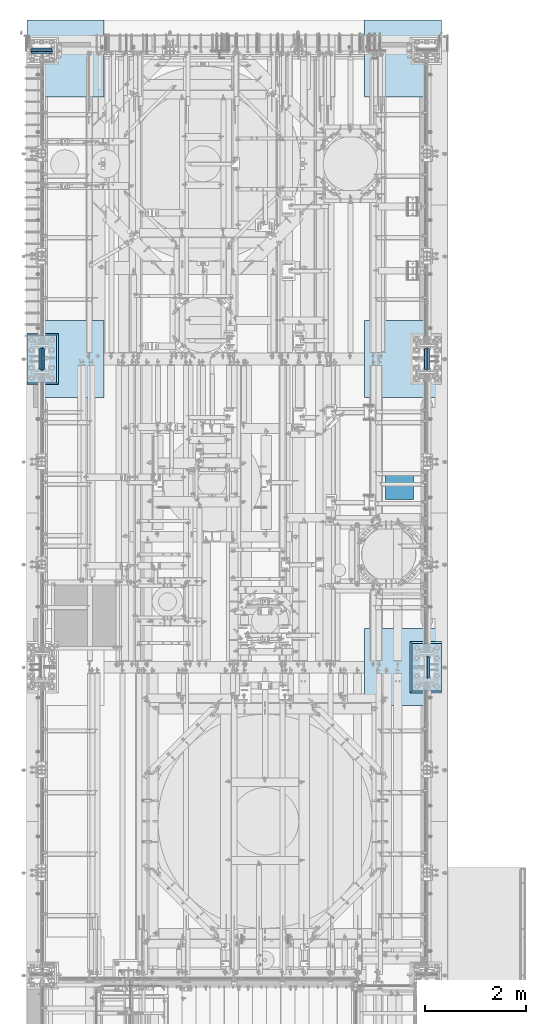
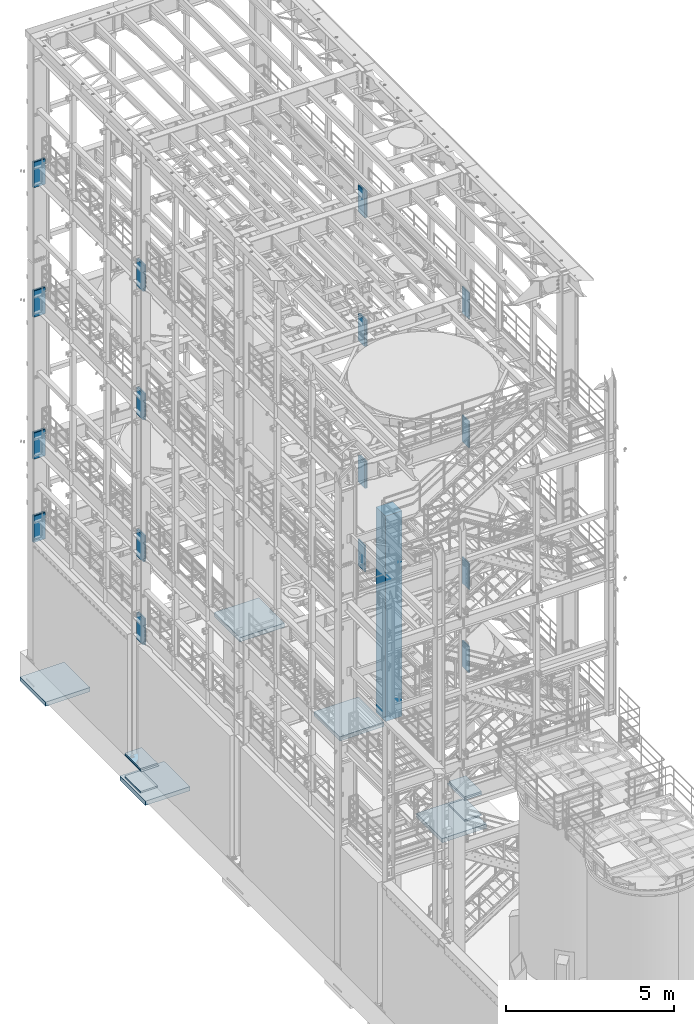
# One storey, part 1403 of 1876: 34 plates, 5 slabs, 18 elements without a shape of their own.
"""IFC2X3 building model written with IfcOpenShell, lengths in millimetres."""

from ifc_helpers import new_model, si_unit, frame, origin_with_axes, place, context, subcontext, project, spatial, faceted_brep, material, type_object, element, aggregate, save


model = new_model("IFC2X3")

# Units and contexts
model_context = context("Model", 3, precision=1e-05, world=origin_with_axes())
body_context = subcontext(model_context, "Body", "Model", "MODEL_VIEW")
ifc_project = project(units=[si_unit("LENGTHUNIT", "METRE", prefix="MILLI"), si_unit("AREAUNIT", "SQUARE_METRE"), si_unit("VOLUMEUNIT", "CUBIC_METRE"), si_unit("MASSUNIT", "GRAM", prefix="KILO"), si_unit("TIMEUNIT", "SECOND"), si_unit("PLANEANGLEUNIT", "RADIAN"), si_unit("SOLIDANGLEUNIT", "STERADIAN"), si_unit("THERMODYNAMICTEMPERATUREUNIT", "DEGREE_CELSIUS"), si_unit("LUMINOUSINTENSITYUNIT", "LUMEN")], contexts=[model_context])

# Site, building, storey
site_placement = place(None, origin_with_axes())
site = spatial("IfcSite", under=ifc_project, at=site_placement, CompositionType="ELEMENT")
building_placement = place(site_placement, origin_with_axes())
building = spatial("IfcBuilding", under=site, at=building_placement, Name="Undefined", CompositionType="ELEMENT")
storey_placement = place(building_placement, origin_with_axes())
storey = spatial("IfcBuildingStorey", under=building, at=storey_placement, Name="Undefined", CompositionType="ELEMENT", Elevation=0.0)

# Assembly, plate
assembly_1_placement = place(storey_placement, origin_with_axes())
assembly_1 = element("IfcElementAssembly", 1, at=assembly_1_placement, inside=storey, Name="PLATE", AssemblyPlace="NOTDEFINED", PredefinedType="RIGID_FRAME")
ifc_material_1 = material(Name="STEEL/A36")
plate_type_1 = type_object("IfcPlateType", PredefinedType="NOTDEFINED")
plate_1_placement = place(assembly_1_placement, frame((6797.675, 5395.9125, 4456.90625), z_axis=(1.0, 0.0, 0.0), x_axis=(0.0, -1.0, 0.0)))
plate_1 = element("IfcPlate", 2, at=plate_1_placement, type_object=plate_type_1, material=ifc_material_1, Name="PLATE", context=body_context, shape_type="Brep", body=[
    faceted_brep([(0.0, -3733.8, 0.0), (0.0, -3733.8, 558.799926757812), (0.0, 3733.8, 558.799926757812), (0.0, 3733.8, 0.0), (558.799926757812, -3733.8, 558.799926757812), (558.799926757812, 3733.8, 558.799926757812), (558.799926757812, -3733.8, 0.0), (558.799926757812, 3733.8, 0.0)], [[[0, 1, 2, 3]], [[1, 4, 5, 2]], [[4, 6, 7, 5]], [[6, 0, 3, 7]], [[5, 7, 3, 2]], [[6, 4, 1, 0]]]),
])
aggregate(assembly_1, [plate_1])

assembly_2_placement = place(storey_placement, origin_with_axes())
assembly_2 = element("IfcElementAssembly", 3, at=assembly_2_placement, inside=storey, Name="COLUMN", AssemblyPlace="NOTDEFINED", PredefinedType="RIGID_FRAME")
ifc_material_2 = material(Name="STEEL/A572-GR.50")
plate_type_2 = type_object("IfcPlateType", PredefinedType="NOTDEFINED")
plate_2_placement = place(assembly_2_placement, frame((7649.36875, 1304.925, 18135.6), z_axis=(0.0, 1.0, 0.0), x_axis=(0.0, 0.0, -1.0)))
plate_2 = element("IfcPlate", 4, at=plate_2_placement, type_object=plate_type_2, material=ifc_material_2, Name="PLATE", context=body_context, shape_type="Brep", body=[
    faceted_brep([(0.0, -19.0500000000002, 416.152954749452), (952.5, -19.0500000000002, 416.152954749464), (952.5, 19.0500000000002, 438.149993896484), (0.0, 19.0500000000002, 438.149993896484), (952.5, -19.0500000000002, 21.997045250647), (952.5, 19.0500000000002, 0.0), (-9.09494701772928e-13, 19.05, -1.81898940354586e-12), (0.0, -19.0500000000002, 21.9970452506512)], [[[0, 1, 2, 3]], [[2, 1, 4, 5]], [[3, 2, 5, 6]], [[0, 3, 6, 7]], [[1, 0, 7, 4]], [[6, 5, 4, 7]]]),
])
aggregate(assembly_2, [plate_2])

# Assembly, plates
assembly_3_placement = place(storey_placement, origin_with_axes())
assembly_3 = element("IfcElementAssembly", 5, at=assembly_3_placement, inside=storey, Name="COLUMN", AssemblyPlace="NOTDEFINED", PredefinedType="RIGID_FRAME")
plate_3_placement = place(assembly_3_placement, frame((7590.63125, 7400.925, 18135.6), z_axis=(0.0, 1.0, 0.0), x_axis=(0.0, 0.0, -1.0)))
plate_3 = element("IfcPlate", 6, at=plate_3_placement, type_object=plate_type_2, material=ifc_material_2, Name="PLATE", context=body_context, shape_type="Brep", body=[
    faceted_brep([(0.0, 19.0500000000002, 416.152954742277), (0.0, -19.0500000000002, 438.149993896484), (952.5, -19.0500000000002, 438.149993896484), (952.5, 19.0500000000002, 416.152954742277), (952.5, 19.0500000000002, 21.9970452577367), (0.0, 19.0500000000002, 21.9970452577367), (0.0, -19.0500000000002, 0.0), (952.5, -19.0500000000002, 0.0)], [[[0, 1, 2, 3]], [[0, 3, 4, 5]], [[1, 0, 5, 6]], [[2, 1, 6, 7]], [[3, 2, 7, 4]], [[6, 5, 4, 7]]]),
])
plate_4_placement = place(assembly_3_placement, frame((7649.36875, 7400.925, 18135.6), z_axis=(0.0, 1.0, 0.0), x_axis=(0.0, 0.0, -1.0)))
plate_4 = element("IfcPlate", 7, at=plate_4_placement, type_object=plate_type_2, material=ifc_material_2, Name="PLATE", context=body_context, shape_type="Brep", body=[
    faceted_brep([(0.0, -19.0500000000002, 416.152954749452), (952.5, -19.0500000000002, 416.152954749464), (952.5, 19.0500000000002, 438.149993896484), (0.0, 19.0500000000002, 438.149993896484), (952.5, -19.0500000000002, 21.997045250647), (952.5, 19.0500000000002, 0.0), (-9.09494701772928e-13, 19.05, -1.81898940354586e-12), (0.0, -19.0500000000002, 21.9970452506512)], [[[0, 1, 2, 3]], [[2, 1, 4, 5]], [[3, 2, 5, 6]], [[0, 3, 6, 7]], [[1, 0, 7, 4]], [[6, 5, 4, 7]]]),
])
aggregate(assembly_3, [plate_3, plate_4])

assembly_4_placement = place(storey_placement, origin_with_axes())
assembly_4 = element("IfcElementAssembly", 8, at=assembly_4_placement, inside=storey, Name="COLUMN", AssemblyPlace="NOTDEFINED", PredefinedType="RIGID_FRAME")
plate_5_placement = place(assembly_4_placement, frame((219.075, 13685.04375, 18135.6), z_axis=(-1.0, 0.0, 0.0), x_axis=(0.0, 0.0, -1.0)))
plate_5 = element("IfcPlate", 9, at=plate_5_placement, type_object=plate_type_2, material=ifc_material_2, Name="PLATE", context=body_context, shape_type="Brep", body=[
    faceted_brep([(0.0, 19.0500000000002, 416.152954742277), (0.0, -19.0500000000002, 438.149993896484), (920.75, -19.0500000000002, 438.149993896484), (920.75, 19.0500000000002, 416.152954742198), (920.75, 19.0500000000002, 21.9970452577326), (0.0, 19.0500000000002, 21.9970452577367), (0.0, -19.0500000000002, 0.0), (920.75, -19.0500000000002, 0.0)], [[[0, 1, 2, 3]], [[0, 3, 4, 5]], [[1, 0, 5, 6]], [[2, 1, 6, 7]], [[3, 2, 7, 4]], [[6, 5, 4, 7]]]),
])
plate_6_placement = place(assembly_4_placement, frame((219.075, 13746.95625, 18135.6), z_axis=(-1.0, 0.0, 0.0), x_axis=(0.0, 0.0, -1.0)))
plate_6 = element("IfcPlate", 10, at=plate_6_placement, type_object=plate_type_2, material=ifc_material_2, Name="PLATE", context=body_context, shape_type="Brep", body=[
    faceted_brep([(0.0, -19.0500000000002, 416.152954749452), (920.75, -19.0500000000002, 416.152954749452), (920.75, 19.0500000000002, 438.149993896484), (0.0, 19.0500000000002, 438.149993896484), (920.75, -19.0500000000002, 21.9970452506512), (920.75, 19.0500000000002, 0.0), (-9.09494701772928e-13, 19.05, -1.81898940354586e-12), (0.0, -19.0500000000002, 21.9970452506512)], [[[0, 1, 2, 3]], [[2, 1, 4, 5]], [[3, 2, 5, 6]], [[0, 3, 6, 7]], [[1, 0, 7, 4]], [[6, 5, 4, 7]]]),
])
aggregate(assembly_4, [plate_5, plate_6])

assembly_5_placement = place(storey_placement, origin_with_axes())
assembly_5 = element("IfcElementAssembly", 11, at=assembly_5_placement, inside=storey, Name="COLUMN", AssemblyPlace="NOTDEFINED", PredefinedType="RIGID_FRAME")
plate_7_placement = place(assembly_5_placement, frame((29.3687499999999, 7839.075, 18135.6), z_axis=(0.0, -1.0, 0.0), x_axis=(0.0, 0.0, -1.0)))
plate_7 = element("IfcPlate", 12, at=plate_7_placement, type_object=plate_type_2, material=ifc_material_2, Name="PLATE", context=body_context, shape_type="Brep", body=[
    faceted_brep([(0.0, 19.0500000000002, 416.152954742277), (0.0, -19.0500000000002, 438.149993896484), (952.5, -19.0500000000002, 438.149993896484), (952.5, 19.0500000000002, 416.152954742277), (952.5, 19.0500000000002, 21.9970452577367), (0.0, 19.0500000000002, 21.9970452577367), (0.0, -19.0500000000002, 0.0), (952.5, -19.0500000000002, 0.0)], [[[0, 1, 2, 3]], [[0, 3, 4, 5]], [[1, 0, 5, 6]], [[2, 1, 6, 7]], [[3, 2, 7, 4]], [[6, 5, 4, 7]]]),
])
plate_8_placement = place(assembly_5_placement, frame((-29.3687499999999, 7839.075, 18135.6), z_axis=(0.0, -1.0, 0.0), x_axis=(0.0, 0.0, -1.0)))
plate_8 = element("IfcPlate", 13, at=plate_8_placement, type_object=plate_type_2, material=ifc_material_2, Name="PLATE", context=body_context, shape_type="Brep", body=[
    faceted_brep([(0.0, -19.0500000000002, 416.152954749452), (952.5, -19.0500000000002, 416.152954749464), (952.5, 19.0500000000002, 438.149993896484), (0.0, 19.0500000000002, 438.149993896484), (952.5, -19.0500000000002, 21.997045250647), (952.5, 19.0500000000002, 0.0), (-9.09494701772928e-13, 19.05, -1.81898940354586e-12), (0.0, -19.0500000000002, 21.9970452506512)], [[[0, 1, 2, 3]], [[2, 1, 4, 5]], [[3, 2, 5, 6]], [[0, 3, 6, 7]], [[1, 0, 7, 4]], [[6, 5, 4, 7]]]),
])
aggregate(assembly_5, [plate_7, plate_8])

assembly_6_placement = place(storey_placement, origin_with_axes())
assembly_6 = element("IfcElementAssembly", 14, at=assembly_6_placement, inside=storey, Name="COLUMN", AssemblyPlace="NOTDEFINED", PredefinedType="RIGID_FRAME")
plate_9_placement = place(assembly_6_placement, frame((29.3687499999999, 7839.075, 13462.0), z_axis=(0.0, -1.0, 0.0), x_axis=(0.0, 0.0, -1.0)))
plate_9 = element("IfcPlate", 15, at=plate_9_placement, type_object=plate_type_2, material=ifc_material_2, Name="PLATE", context=body_context, shape_type="Brep", body=[
    faceted_brep([(0.0, 19.0500000000002, 416.152954742277), (0.0, -19.0500000000002, 438.149993896484), (952.5, -19.0500000000002, 438.149993896484), (952.5, 19.0500000000002, 416.152954742277), (952.5, 19.0500000000002, 21.9970452577367), (0.0, 19.0500000000002, 21.9970452577367), (0.0, -19.0500000000002, 0.0), (952.5, -19.0500000000002, 0.0)], [[[0, 1, 2, 3]], [[0, 3, 4, 5]], [[1, 0, 5, 6]], [[2, 1, 6, 7]], [[3, 2, 7, 4]], [[6, 5, 4, 7]]]),
])
plate_10_placement = place(assembly_6_placement, frame((-29.3687499999999, 7839.075, 13462.0), z_axis=(0.0, -1.0, 0.0), x_axis=(0.0, 0.0, -1.0)))
plate_10 = element("IfcPlate", 16, at=plate_10_placement, type_object=plate_type_2, material=ifc_material_2, Name="PLATE", context=body_context, shape_type="Brep", body=[
    faceted_brep([(0.0, -19.0500000000002, 416.152954749452), (952.5, -19.0500000000002, 416.152954749464), (952.5, 19.0500000000002, 438.149993896484), (0.0, 19.0500000000002, 438.149993896484), (952.5, -19.0500000000002, 21.997045250647), (952.5, 19.0500000000002, 0.0), (-9.09494701772928e-13, 19.05, -1.81898940354586e-12), (0.0, -19.0500000000002, 21.9970452506512)], [[[0, 1, 2, 3]], [[2, 1, 4, 5]], [[3, 2, 5, 6]], [[0, 3, 6, 7]], [[1, 0, 7, 4]], [[6, 5, 4, 7]]]),
])
plate_11_placement = place(assembly_6_placement, frame((29.3687499999999, 7839.075, 8305.8), z_axis=(0.0, -1.0, 0.0), x_axis=(0.0, 0.0, -1.0)))
plate_11 = element("IfcPlate", 17, at=plate_11_placement, type_object=plate_type_2, material=ifc_material_2, Name="PLATE", context=body_context, shape_type="Brep", body=[
    faceted_brep([(0.0, 19.0500000000002, 416.152954742277), (0.0, -19.0500000000002, 438.149993896484), (952.5, -19.0500000000002, 438.149993896484), (952.5, 19.0500000000002, 416.152954742277), (952.5, 19.0500000000002, 21.9970452577367), (0.0, 19.0500000000002, 21.9970452577367), (0.0, -19.0500000000002, 0.0), (952.5, -19.0500000000002, 0.0)], [[[0, 1, 2, 3]], [[0, 3, 4, 5]], [[1, 0, 5, 6]], [[2, 1, 6, 7]], [[3, 2, 7, 4]], [[6, 5, 4, 7]]]),
])
plate_12_placement = place(assembly_6_placement, frame((-29.3687499999999, 7839.075, 8305.8), z_axis=(0.0, -1.0, 0.0), x_axis=(0.0, 0.0, -1.0)))
plate_12 = element("IfcPlate", 18, at=plate_12_placement, type_object=plate_type_2, material=ifc_material_2, Name="PLATE", context=body_context, shape_type="Brep", body=[
    faceted_brep([(0.0, -19.0500000000002, 416.152954749452), (952.5, -19.0500000000002, 416.152954749464), (952.5, 19.0500000000002, 438.149993896484), (0.0, 19.0500000000002, 438.149993896484), (952.5, -19.0500000000002, 21.997045250647), (952.5, 19.0500000000002, 0.0), (-9.09494701772928e-13, 19.05, -1.81898940354586e-12), (0.0, -19.0500000000002, 21.9970452506512)], [[[0, 1, 2, 3]], [[2, 1, 4, 5]], [[3, 2, 5, 6]], [[0, 3, 6, 7]], [[1, 0, 7, 4]], [[6, 5, 4, 7]]]),
])

# Assembly, plate
assembly_7_placement = place(storey_placement, origin_with_axes())
assembly_7 = element("IfcElementAssembly", 19, at=assembly_7_placement, inside=storey, Name="COLUMN", AssemblyPlace="NOTDEFINED", PredefinedType="RIGID_FRAME")
plate_13_placement = place(assembly_7_placement, frame((7649.36875, 1304.925, 13462.0), z_axis=(0.0, 1.0, 0.0), x_axis=(0.0, 0.0, -1.0)))
plate_13 = element("IfcPlate", 20, at=plate_13_placement, type_object=plate_type_2, material=ifc_material_2, Name="PLATE", context=body_context, shape_type="Brep", body=[
    faceted_brep([(0.0, -19.0500000000002, 416.152954749452), (952.5, -19.0500000000002, 416.152954749464), (952.5, 19.0500000000002, 438.149993896484), (0.0, 19.0500000000002, 438.149993896484), (952.5, -19.0500000000002, 21.997045250647), (952.5, 19.0500000000002, 0.0), (-9.09494701772928e-13, 19.05, -1.81898940354586e-12), (0.0, -19.0500000000002, 21.9970452506512)], [[[0, 1, 2, 3]], [[2, 1, 4, 5]], [[3, 2, 5, 6]], [[0, 3, 6, 7]], [[1, 0, 7, 4]], [[6, 5, 4, 7]]]),
])

# Assembly, plates
assembly_8_placement = place(storey_placement, origin_with_axes())
assembly_8 = element("IfcElementAssembly", 21, at=assembly_8_placement, inside=storey, Name="COLUMN", AssemblyPlace="NOTDEFINED", PredefinedType="RIGID_FRAME")
plate_14_placement = place(assembly_8_placement, frame((7590.63125, 7400.925, 13462.0), z_axis=(0.0, 1.0, 0.0), x_axis=(0.0, 0.0, -1.0)))
plate_14 = element("IfcPlate", 22, at=plate_14_placement, type_object=plate_type_2, material=ifc_material_2, Name="PLATE", context=body_context, shape_type="Brep", body=[
    faceted_brep([(0.0, 19.0500000000002, 416.152954742277), (0.0, -19.0500000000002, 438.149993896484), (952.5, -19.0500000000002, 438.149993896484), (952.5, 19.0500000000002, 416.152954742277), (952.5, 19.0500000000002, 21.9970452577367), (0.0, 19.0500000000002, 21.9970452577367), (0.0, -19.0500000000002, 0.0), (952.5, -19.0500000000002, 0.0)], [[[0, 1, 2, 3]], [[0, 3, 4, 5]], [[1, 0, 5, 6]], [[2, 1, 6, 7]], [[3, 2, 7, 4]], [[6, 5, 4, 7]]]),
])
plate_15_placement = place(assembly_8_placement, frame((7649.36875, 7400.925, 13462.0), z_axis=(0.0, 1.0, 0.0), x_axis=(0.0, 0.0, -1.0)))
plate_15 = element("IfcPlate", 23, at=plate_15_placement, type_object=plate_type_2, material=ifc_material_2, Name="PLATE", context=body_context, shape_type="Brep", body=[
    faceted_brep([(0.0, -19.0500000000002, 416.152954749452), (952.5, -19.0500000000002, 416.152954749464), (952.5, 19.0500000000002, 438.149993896484), (0.0, 19.0500000000002, 438.149993896484), (952.5, -19.0500000000002, 21.997045250647), (952.5, 19.0500000000002, 0.0), (-9.09494701772928e-13, 19.05, -1.81898940354586e-12), (0.0, -19.0500000000002, 21.9970452506512)], [[[0, 1, 2, 3]], [[2, 1, 4, 5]], [[3, 2, 5, 6]], [[0, 3, 6, 7]], [[1, 0, 7, 4]], [[6, 5, 4, 7]]]),
])

assembly_9_placement = place(storey_placement, origin_with_axes())
assembly_9 = element("IfcElementAssembly", 24, at=assembly_9_placement, inside=storey, Name="COLUMN", AssemblyPlace="NOTDEFINED", PredefinedType="RIGID_FRAME")
plate_16_placement = place(assembly_9_placement, frame((219.075, 13685.04375, 13462.0), z_axis=(-1.0, 0.0, 0.0), x_axis=(0.0, 0.0, -1.0)))
plate_16 = element("IfcPlate", 25, at=plate_16_placement, type_object=plate_type_2, material=ifc_material_2, Name="PLATE", context=body_context, shape_type="Brep", body=[
    faceted_brep([(0.0, 19.0500000000002, 416.152954742277), (0.0, -19.0500000000002, 438.149993896484), (952.5, -19.0500000000002, 438.149993896484), (952.5, 19.0500000000002, 416.152954742277), (952.5, 19.0500000000002, 21.9970452577367), (0.0, 19.0500000000002, 21.9970452577367), (0.0, -19.0500000000002, 0.0), (952.5, -19.0500000000002, 0.0)], [[[0, 1, 2, 3]], [[0, 3, 4, 5]], [[1, 0, 5, 6]], [[2, 1, 6, 7]], [[3, 2, 7, 4]], [[6, 5, 4, 7]]]),
])
plate_17_placement = place(assembly_9_placement, frame((219.075, 13746.95625, 13462.0), z_axis=(-1.0, 0.0, 0.0), x_axis=(0.0, 0.0, -1.0)))
plate_17 = element("IfcPlate", 26, at=plate_17_placement, type_object=plate_type_2, material=ifc_material_2, Name="PLATE", context=body_context, shape_type="Brep", body=[
    faceted_brep([(0.0, -19.0500000000002, 416.152954749452), (952.5, -19.0500000000002, 416.152954749464), (952.5, 19.0500000000002, 438.149993896484), (0.0, 19.0500000000002, 438.149993896484), (952.5, -19.0500000000002, 21.997045250647), (952.5, 19.0500000000002, 0.0), (-9.09494701772928e-13, 19.05, -1.81898940354586e-12), (0.0, -19.0500000000002, 21.9970452506512)], [[[0, 1, 2, 3]], [[2, 1, 4, 5]], [[3, 2, 5, 6]], [[0, 3, 6, 7]], [[1, 0, 7, 4]], [[6, 5, 4, 7]]]),
])

# Plate
plate_18_placement = place(assembly_7_placement, frame((7649.36875, 1304.925, 8305.8), z_axis=(0.0, 1.0, 0.0), x_axis=(0.0, 0.0, -1.0)))
plate_18 = element("IfcPlate", 27, at=plate_18_placement, type_object=plate_type_2, material=ifc_material_2, Name="PLATE", context=body_context, shape_type="Brep", body=[
    faceted_brep([(0.0, -19.0500000000002, 416.152954749452), (952.5, -19.0500000000002, 416.152954749464), (952.5, 19.0500000000002, 438.149993896484), (0.0, 19.0500000000002, 438.149993896484), (952.5, -19.0500000000002, 21.997045250647), (952.5, 19.0500000000002, 0.0), (-9.09494701772928e-13, 19.05, -1.81898940354586e-12), (0.0, -19.0500000000002, 21.9970452506512)], [[[0, 1, 2, 3]], [[2, 1, 4, 5]], [[3, 2, 5, 6]], [[0, 3, 6, 7]], [[1, 0, 7, 4]], [[6, 5, 4, 7]]]),
])

plate_19_placement = place(assembly_8_placement, frame((7590.63125, 7400.925, 8305.8), z_axis=(0.0, 1.0, 0.0), x_axis=(0.0, 0.0, -1.0)))
plate_19 = element("IfcPlate", 28, at=plate_19_placement, type_object=plate_type_2, material=ifc_material_2, Name="PLATE", context=body_context, shape_type="Brep", body=[
    faceted_brep([(0.0, 19.0500000000002, 416.152954742277), (0.0, -19.0500000000002, 438.149993896484), (952.5, -19.0500000000002, 438.149993896484), (952.5, 19.0500000000002, 416.152954742277), (952.5, 19.0500000000002, 21.9970452577367), (0.0, 19.0500000000002, 21.9970452577367), (0.0, -19.0500000000002, 0.0), (952.5, -19.0500000000002, 0.0)], [[[0, 1, 2, 3]], [[0, 3, 4, 5]], [[1, 0, 5, 6]], [[2, 1, 6, 7]], [[3, 2, 7, 4]], [[6, 5, 4, 7]]]),
])

plate_20_placement = place(assembly_8_placement, frame((7649.36875, 7400.925, 8305.8), z_axis=(0.0, 1.0, 0.0), x_axis=(0.0, 0.0, -1.0)))
plate_20 = element("IfcPlate", 29, at=plate_20_placement, type_object=plate_type_2, material=ifc_material_2, Name="PLATE", context=body_context, shape_type="Brep", body=[
    faceted_brep([(0.0, -19.0500000000002, 416.152954749452), (952.5, -19.0500000000002, 416.152954749464), (952.5, 19.0500000000002, 438.149993896484), (0.0, 19.0500000000002, 438.149993896484), (952.5, -19.0500000000002, 21.997045250647), (952.5, 19.0500000000002, 0.0), (-9.09494701772928e-13, 19.05, -1.81898940354586e-12), (0.0, -19.0500000000002, 21.9970452506512)], [[[0, 1, 2, 3]], [[2, 1, 4, 5]], [[3, 2, 5, 6]], [[0, 3, 6, 7]], [[1, 0, 7, 4]], [[6, 5, 4, 7]]]),
])

plate_21_placement = place(assembly_7_placement, frame((7649.36875, 1304.925, 5283.2), z_axis=(0.0, 1.0, 0.0), x_axis=(0.0, 0.0, -1.0)))
plate_21 = element("IfcPlate", 30, at=plate_21_placement, type_object=plate_type_2, material=ifc_material_2, Name="PLATE", context=body_context, shape_type="Brep", body=[
    faceted_brep([(0.0, -19.0500000000002, 416.152954749452), (952.5, -19.0500000000002, 416.152954749464), (952.5, 19.0500000000002, 438.149993896484), (0.0, 19.0500000000002, 438.149993896484), (952.5, -19.0500000000002, 21.997045250647), (952.5, 19.0500000000002, 0.0), (-9.09494701772928e-13, 19.05, -1.81898940354586e-12), (0.0, -19.0500000000002, 21.9970452506512)], [[[0, 1, 2, 3]], [[2, 1, 4, 5]], [[3, 2, 5, 6]], [[0, 3, 6, 7]], [[1, 0, 7, 4]], [[6, 5, 4, 7]]]),
])

plate_22_placement = place(assembly_8_placement, frame((7590.63125, 7400.925, 5283.2), z_axis=(0.0, 1.0, 0.0), x_axis=(0.0, 0.0, -1.0)))
plate_22 = element("IfcPlate", 31, at=plate_22_placement, type_object=plate_type_2, material=ifc_material_2, Name="PLATE", context=body_context, shape_type="Brep", body=[
    faceted_brep([(0.0, 19.0500000000002, 416.152954742277), (0.0, -19.0500000000002, 438.149993896484), (952.5, -19.0500000000002, 438.149993896484), (952.5, 19.0500000000002, 416.152954742277), (952.5, 19.0500000000002, 21.9970452577367), (0.0, 19.0500000000002, 21.9970452577367), (0.0, -19.0500000000002, 0.0), (952.5, -19.0500000000002, 0.0)], [[[0, 1, 2, 3]], [[0, 3, 4, 5]], [[1, 0, 5, 6]], [[2, 1, 6, 7]], [[3, 2, 7, 4]], [[6, 5, 4, 7]]]),
])

aggregate(assembly_8, [plate_14, plate_15, plate_19, plate_20, plate_22])

plate_23_placement = place(assembly_6_placement, frame((29.3687499999999, 7839.075, 5283.2), z_axis=(0.0, -1.0, 0.0), x_axis=(0.0, 0.0, -1.0)))
plate_23 = element("IfcPlate", 32, at=plate_23_placement, type_object=plate_type_2, material=ifc_material_2, Name="PLATE", context=body_context, shape_type="Brep", body=[
    faceted_brep([(0.0, 19.0500000000002, 416.152954742277), (0.0, -19.0500000000002, 438.149993896484), (952.5, -19.0500000000002, 438.149993896484), (952.5, 19.0500000000002, 416.152954742277), (952.5, 19.0500000000002, 21.9970452577367), (0.0, 19.0500000000002, 21.9970452577367), (0.0, -19.0500000000002, 0.0), (952.5, -19.0500000000002, 0.0)], [[[0, 1, 2, 3]], [[0, 3, 4, 5]], [[1, 0, 5, 6]], [[2, 1, 6, 7]], [[3, 2, 7, 4]], [[6, 5, 4, 7]]]),
])

plate_24_placement = place(assembly_6_placement, frame((-29.3687499999999, 7839.075, 5283.2), z_axis=(0.0, -1.0, 0.0), x_axis=(0.0, 0.0, -1.0)))
plate_24 = element("IfcPlate", 33, at=plate_24_placement, type_object=plate_type_2, material=ifc_material_2, Name="PLATE", context=body_context, shape_type="Brep", body=[
    faceted_brep([(0.0, -19.0500000000002, 416.152954749452), (952.5, -19.0500000000002, 416.152954749464), (952.5, 19.0500000000002, 438.149993896484), (0.0, 19.0500000000002, 438.149993896484), (952.5, -19.0500000000002, 21.997045250647), (952.5, 19.0500000000002, 0.0), (-9.09494701772928e-13, 19.05, -1.81898940354586e-12), (0.0, -19.0500000000002, 21.9970452506512)], [[[0, 1, 2, 3]], [[2, 1, 4, 5]], [[3, 2, 5, 6]], [[0, 3, 6, 7]], [[1, 0, 7, 4]], [[6, 5, 4, 7]]]),
])

plate_type_3 = type_object("IfcPlateType", PredefinedType="NOTDEFINED")
plate_25_placement = place(assembly_9_placement, frame((219.075, 13681.86875, 8305.8), z_axis=(-1.0, 0.0, 0.0), x_axis=(0.0, 0.0, -1.0)))
plate_25 = element("IfcPlate", 34, at=plate_25_placement, type_object=plate_type_3, material=ifc_material_2, Name="PLATE", context=body_context, shape_type="Brep", body=[
    faceted_brep([(0.0, 22.2250000000004, 412.486780532837), (0.0, -22.2250000000004, 438.149993896484), (952.5, -22.2250000000004, 438.149993896484), (952.5, 22.2250000000004, 412.486780532837), (952.5, 22.2250000000004, 25.663219467172), (0.0, 22.2250000000004, 25.663219467172), (0.0, -22.2250000000004, 0.0), (952.5, -22.2250000000004, 0.0)], [[[0, 1, 2, 3]], [[0, 3, 4, 5]], [[1, 0, 5, 6]], [[2, 1, 6, 7]], [[3, 2, 7, 4]], [[6, 5, 4, 7]]]),
])

plate_26_placement = place(assembly_9_placement, frame((219.075, 13750.13125, 8305.8), z_axis=(-1.0, 0.0, 0.0), x_axis=(0.0, 0.0, -1.0)))
plate_26 = element("IfcPlate", 35, at=plate_26_placement, type_object=plate_type_3, material=ifc_material_2, Name="PLATE", context=body_context, shape_type="Brep", body=[
    faceted_brep([(0.0, -22.2250000000004, 412.486780540907), (952.5, -22.2250000000004, 412.486780540907), (952.5, 22.2250000000004, 438.149993896484), (0.0, 22.2250000000004, 438.149993896484), (952.5, -22.2250000000004, 25.6632194590944), (952.5, 22.2250000000004, 0.0), (0.0, 22.2250000000004, 0.0), (0.0, -22.2250000000004, 25.6632194590944)], [[[0, 1, 2, 3]], [[2, 1, 4, 5]], [[3, 2, 5, 6]], [[0, 3, 6, 7]], [[1, 0, 7, 4]], [[6, 5, 4, 7]]]),
])

plate_27_placement = place(assembly_9_placement, frame((219.075, 13681.86875, 5283.2), z_axis=(-1.0, 0.0, 0.0), x_axis=(0.0, 0.0, -1.0)))
plate_27 = element("IfcPlate", 36, at=plate_27_placement, type_object=plate_type_3, material=ifc_material_2, Name="PLATE", context=body_context, shape_type="Brep", body=[
    faceted_brep([(0.0, 22.2250000000004, 412.486780532837), (0.0, -22.2250000000004, 438.149993896484), (952.5, -22.2250000000004, 438.149993896484), (952.5, 22.2250000000004, 412.486780532837), (952.5, 22.2250000000004, 25.663219467172), (0.0, 22.2250000000004, 25.663219467172), (0.0, -22.2250000000004, 0.0), (952.5, -22.2250000000004, 0.0)], [[[0, 1, 2, 3]], [[0, 3, 4, 5]], [[1, 0, 5, 6]], [[2, 1, 6, 7]], [[3, 2, 7, 4]], [[6, 5, 4, 7]]]),
])

plate_28_placement = place(assembly_9_placement, frame((219.075, 13750.13125, 5283.2), z_axis=(-1.0, 0.0, 0.0), x_axis=(0.0, 0.0, -1.0)))
plate_28 = element("IfcPlate", 37, at=plate_28_placement, type_object=plate_type_3, material=ifc_material_2, Name="PLATE", context=body_context, shape_type="Brep", body=[
    faceted_brep([(0.0, -22.2250000000004, 412.486780540907), (952.5, -22.2250000000004, 412.486780540907), (952.5, 22.2250000000004, 438.149993896484), (0.0, 22.2250000000004, 438.149993896484), (952.5, -22.2250000000004, 25.6632194590944), (952.5, 22.2250000000004, 0.0), (0.0, 22.2250000000004, 0.0), (0.0, -22.2250000000004, 25.6632194590944)], [[[0, 1, 2, 3]], [[2, 1, 4, 5]], [[3, 2, 5, 6]], [[0, 3, 6, 7]], [[1, 0, 7, 4]], [[6, 5, 4, 7]]]),
])

aggregate(assembly_9, [plate_16, plate_17, plate_25, plate_26, plate_27, plate_28])

# Assembly, slab
assembly_10_placement = place(storey_placement, origin_with_axes())
assembly_10 = element("IfcElementAssembly", 38, at=assembly_10_placement, inside=storey, Name="SLAB", AssemblyPlace="NOTDEFINED", PredefinedType="REINFORCEMENT_UNIT")
ifc_material_3 = material(Name="CONCRETE/3000")
slab_type = type_object("IfcSlabType", PredefinedType="NOTDEFINED")
slab_1_placement = place(assembly_10_placement, frame((7912.0998046875, 14325.6, -990.6), z_axis=(0.0, -1.0, 0.0), x_axis=(-1.0, 0.0, 0.0)))
slab_1 = element("IfcSlab", 39, at=slab_1_placement, type_object=slab_type, material=ifc_material_3, Name="SLAB", PredefinedType="FLOOR", context=body_context, shape_type="Brep", body=[
    faceted_brep([(0.0, -76.2, 0.0), (9.09494701772928e-13, -76.2, 1524.0), (9.09494701772928e-13, 76.2, 1524.0), (0.0, 76.2, 0.0), (1524.0, -76.2, 1524.0), (1524.0, 76.2, 1524.0), (1524.0, -76.2, 0.0), (1524.0, 76.2, 0.0)], [[[0, 1, 2, 3]], [[1, 4, 5, 2]], [[4, 6, 7, 5]], [[6, 0, 3, 7]], [[5, 7, 3, 2]], [[6, 4, 1, 0]]]),
])
aggregate(assembly_10, [slab_1])

assembly_11_placement = place(storey_placement, origin_with_axes())
assembly_11 = element("IfcElementAssembly", 40, at=assembly_11_placement, inside=storey, Name="SLAB", AssemblyPlace="NOTDEFINED", PredefinedType="REINFORCEMENT_UNIT")
slab_2_placement = place(assembly_11_placement, frame((7912.0998046875, 2286.0, -990.6), z_axis=(0.0, -1.0, 0.0), x_axis=(-1.0, 0.0, 0.0)))
slab_2 = element("IfcSlab", 41, at=slab_2_placement, type_object=slab_type, material=ifc_material_3, Name="SLAB", PredefinedType="FLOOR", context=body_context, shape_type="Brep", body=[
    faceted_brep([(0.0, -76.2, 0.0), (9.09494701772928e-13, -76.2, 1524.0), (9.09494701772928e-13, 76.2, 1524.0), (0.0, 76.2, 0.0), (1524.0, -76.2, 1524.0), (1524.0, 76.2, 1524.0), (1524.0, -76.2, 0.0), (1524.0, 76.2, 0.0)], [[[0, 1, 2, 3]], [[1, 4, 5, 2]], [[4, 6, 7, 5]], [[6, 0, 3, 7]], [[5, 7, 3, 2]], [[6, 4, 1, 0]]]),
])
aggregate(assembly_11, [slab_2])

assembly_12_placement = place(storey_placement, origin_with_axes())
assembly_12 = element("IfcElementAssembly", 42, at=assembly_12_placement, inside=storey, Name="SLAB", AssemblyPlace="NOTDEFINED", PredefinedType="REINFORCEMENT_UNIT")
slab_3_placement = place(assembly_12_placement, frame((7912.0998046875, 8382.0, -990.6), z_axis=(0.0, -1.0, 0.0), x_axis=(-1.0, 0.0, 0.0)))
slab_3 = element("IfcSlab", 43, at=slab_3_placement, type_object=slab_type, material=ifc_material_3, Name="SLAB", PredefinedType="FLOOR", context=body_context, shape_type="Brep", body=[
    faceted_brep([(0.0, -76.2, 0.0), (9.09494701772928e-13, -76.2, 1524.0), (9.09494701772928e-13, 76.2, 1524.0), (0.0, 76.2, 0.0), (1524.0, -76.2, 1524.0), (1524.0, 76.2, 1524.0), (1524.0, -76.2, 0.0), (1524.0, 76.2, 0.0)], [[[0, 1, 2, 3]], [[1, 4, 5, 2]], [[4, 6, 7, 5]], [[6, 0, 3, 7]], [[5, 7, 3, 2]], [[6, 4, 1, 0]]]),
])
aggregate(assembly_12, [slab_3])

assembly_13_placement = place(storey_placement, origin_with_axes())
assembly_13 = element("IfcElementAssembly", 44, at=assembly_13_placement, inside=storey, Name="SLAB", AssemblyPlace="NOTDEFINED", PredefinedType="REINFORCEMENT_UNIT")
slab_4_placement = place(assembly_13_placement, frame((1231.9, 8382.0, -990.6), z_axis=(0.0, -1.0, 0.0), x_axis=(-1.0, 0.0, 0.0)))
slab_4 = element("IfcSlab", 45, at=slab_4_placement, type_object=slab_type, material=ifc_material_3, Name="SLAB", PredefinedType="FLOOR", context=body_context, shape_type="Brep", body=[
    faceted_brep([(0.0, -76.2, 0.0), (9.09494701772928e-13, -76.2, 1524.0), (9.09494701772928e-13, 76.2, 1524.0), (0.0, 76.2, 0.0), (1524.0, -76.2, 1524.0), (1524.0, 76.2, 1524.0), (1524.0, -76.2, 0.0), (1524.0, 76.2, 0.0)], [[[0, 1, 2, 3]], [[1, 4, 5, 2]], [[4, 6, 7, 5]], [[6, 0, 3, 7]], [[5, 7, 3, 2]], [[6, 4, 1, 0]]]),
])
aggregate(assembly_13, [slab_4])

assembly_14_placement = place(storey_placement, origin_with_axes())
assembly_14 = element("IfcElementAssembly", 46, at=assembly_14_placement, inside=storey, Name="SLAB", AssemblyPlace="NOTDEFINED", PredefinedType="REINFORCEMENT_UNIT")
slab_5_placement = place(assembly_14_placement, frame((1231.9, 14325.6, -990.6), z_axis=(0.0, -1.0, 0.0), x_axis=(-1.0, 0.0, 0.0)))
slab_5 = element("IfcSlab", 47, at=slab_5_placement, type_object=slab_type, material=ifc_material_3, Name="SLAB", PredefinedType="FLOOR", context=body_context, shape_type="Brep", body=[
    faceted_brep([(0.0, -76.2, 0.0), (9.09494701772928e-13, -76.2, 1524.0), (9.09494701772928e-13, 76.2, 1524.0), (0.0, 76.2, 0.0), (1524.0, -76.2, 1524.0), (1524.0, 76.2, 1524.0), (1524.0, -76.2, 0.0), (1524.0, 76.2, 0.0)], [[[0, 1, 2, 3]], [[1, 4, 5, 2]], [[4, 6, 7, 5]], [[6, 0, 3, 7]], [[5, 7, 3, 2]], [[6, 4, 1, 0]]]),
])
aggregate(assembly_14, [slab_5])

# Assembly, plate
assembly_15_placement = place(storey_placement, origin_with_axes())
assembly_15 = element("IfcElementAssembly", 48, at=assembly_15_placement, inside=storey, Name="TEMPLATE", AssemblyPlace="NOTDEFINED", PredefinedType="RIGID_FRAME")
ifc_material_4 = material(Name="STEEL/A572-50")
plate_type_4 = type_object("IfcPlateType", PredefinedType="NOTDEFINED")
plate_29_placement = place(assembly_15_placement, frame((7327.9, 1993.9, -765.175), z_axis=(1.0, 0.0, 0.0), x_axis=(0.0, -1.0, 0.0)))
plate_29 = element("IfcPlate", 49, at=plate_29_placement, type_object=plate_type_4, material=ifc_material_4, Name="PLATE", context=body_context, shape_type="Brep", body=[
    faceted_brep([(0.0, -28.575, 0.0), (0.0, -28.575, 584.200012207031), (0.0, 28.575, 584.200012207031), (0.0, 28.575, 0.0), (939.799987792969, -28.575, 584.200012207031), (939.799987792969, 28.575, 584.200012207031), (939.799987792969, -28.575, 0.0), (939.799987792969, 28.575, 0.0)], [[[0, 1, 2, 3]], [[1, 4, 5, 2]], [[4, 6, 7, 5]], [[6, 0, 3, 7]], [[5, 7, 3, 2]], [[6, 4, 1, 0]]]),
])
aggregate(assembly_15, [plate_29])

# Plate
plate_30_placement = place(assembly_7_placement, frame((7327.9, 1993.9, 66.675), z_axis=(1.0, 0.0, 0.0), x_axis=(0.0, -1.0, 0.0)))
plate_30 = element("IfcPlate", 50, at=plate_30_placement, type_object=plate_type_4, material=ifc_material_2, Name="PLATE", context=body_context, shape_type="Brep", body=[
    faceted_brep([(0.0, -28.575, 0.0), (0.0, -28.575, 584.200012207031), (0.0, 28.575, 584.200012207031), (0.0, 28.575, 0.0), (939.799987792969, -28.575, 584.200012207031), (939.799987792969, 28.575, 584.200012207031), (939.799987792969, -28.575, 0.0), (939.799987792969, 28.575, 0.0)], [[[0, 1, 2, 3]], [[1, 4, 5, 2]], [[4, 6, 7, 5]], [[6, 0, 3, 7]], [[5, 7, 3, 2]], [[6, 4, 1, 0]]]),
])

aggregate(assembly_7, [plate_13, plate_18, plate_21, plate_30])

# Assembly, plate
assembly_16_placement = place(storey_placement, origin_with_axes())
assembly_16 = element("IfcElementAssembly", 51, at=assembly_16_placement, inside=storey, Name="TEMPLATE", AssemblyPlace="NOTDEFINED", PredefinedType="RIGID_FRAME")
plate_31_placement = place(assembly_16_placement, frame((-292.1, 8089.9, -765.175), z_axis=(1.0, 0.0, 0.0), x_axis=(0.0, -1.0, 0.0)))
plate_31 = element("IfcPlate", 52, at=plate_31_placement, type_object=plate_type_4, material=ifc_material_4, Name="PLATE", context=body_context, shape_type="Brep", body=[
    faceted_brep([(0.0, -28.575, 0.0), (0.0, -28.575, 584.200012207031), (0.0, 28.575, 584.200012207031), (0.0, 28.575, 0.0), (939.799987792969, -28.575, 584.200012207031), (939.799987792969, 28.575, 584.200012207031), (939.799987792969, -28.575, 0.0), (939.799987792969, 28.575, 0.0)], [[[0, 1, 2, 3]], [[1, 4, 5, 2]], [[4, 6, 7, 5]], [[6, 0, 3, 7]], [[5, 7, 3, 2]], [[6, 4, 1, 0]]]),
])
aggregate(assembly_16, [plate_31])

# Plate
plate_32_placement = place(assembly_6_placement, frame((-292.1, 8089.9, 66.675), z_axis=(1.0, 0.0, 0.0), x_axis=(0.0, -1.0, 0.0)))
plate_32 = element("IfcPlate", 53, at=plate_32_placement, type_object=plate_type_4, material=ifc_material_2, Name="PLATE", context=body_context, shape_type="Brep", body=[
    faceted_brep([(0.0, -28.575, 0.0), (0.0, -28.575, 584.200012207031), (0.0, 28.575, 584.200012207031), (0.0, 28.575, 0.0), (939.799987792969, -28.575, 584.200012207031), (939.799987792969, 28.575, 584.200012207031), (939.799987792969, -28.575, 0.0), (939.799987792969, 28.575, 0.0)], [[[0, 1, 2, 3]], [[1, 4, 5, 2]], [[4, 6, 7, 5]], [[6, 0, 3, 7]], [[5, 7, 3, 2]], [[6, 4, 1, 0]]]),
])

aggregate(assembly_6, [plate_9, plate_10, plate_11, plate_12, plate_23, plate_24, plate_32])

# Assembly, plate
assembly_17_placement = place(storey_placement, origin_with_axes())
assembly_17 = element("IfcElementAssembly", 54, at=assembly_17_placement, inside=storey, Name="GROUT", AssemblyPlace="NOTDEFINED", PredefinedType="REINFORCEMENT_UNIT")
ifc_material_5 = material(Name="CONCRETE/Concrete_Undefined")
plate_type_5 = type_object("IfcPlateType", PredefinedType="NOTDEFINED")
plate_33_placement = place(assembly_17_placement, frame((7289.8, 2032.0, 19.05), z_axis=(1.0, 0.0, 0.0), x_axis=(0.0, -1.0, 0.0)))
plate_33 = element("IfcPlate", 55, at=plate_33_placement, type_object=plate_type_5, material=ifc_material_5, Name="GROUT", context=body_context, shape_type="Brep", body=[
    faceted_brep([(1016.0, 19.05, 622.2998046875), (0.0, 19.05, 622.299804687501), (38.0999999999849, -19.05, 622.299999999983), (977.899999999984, -19.05, 622.299999999984), (1016.0, 19.05, 0.0), (977.899999999984, -19.05, 38.1000000000158), (38.1000000120275, -19.05, 38.1000000109725), (-9.09494701772928e-13, 19.05, -1.81898940354586e-12)], [[[0, 1, 2, 3]], [[4, 5, 6, 7]], [[5, 4, 0, 3]], [[6, 5, 3, 2]], [[7, 6, 2, 1]], [[4, 7, 1, 0]]]),
])
aggregate(assembly_17, [plate_33])

assembly_18_placement = place(storey_placement, origin_with_axes())
assembly_18 = element("IfcElementAssembly", 56, at=assembly_18_placement, inside=storey, Name="GROUT", AssemblyPlace="NOTDEFINED", PredefinedType="REINFORCEMENT_UNIT")
plate_34_placement = place(assembly_18_placement, frame((-330.2, 8128.0, 19.05), z_axis=(1.0, 0.0, 0.0), x_axis=(0.0, -1.0, 0.0)))
plate_34 = element("IfcPlate", 57, at=plate_34_placement, type_object=plate_type_5, material=ifc_material_5, Name="GROUT", context=body_context, shape_type="Brep", body=[
    faceted_brep([(1016.0, 19.05, 38.0999984741211), (977.899999999984, -19.05, 38.1000000000158), (38.1000000120275, -19.05, 38.1000000109725), (0.0, 19.0500000000002, 38.1000000000004), (977.899999999984, -19.05, 622.299999999984), (1016.0, 19.05, 660.400024414062), (0.0, 19.05, 660.400024414062), (38.0999999999849, -19.05, 622.299999999983)], [[[0, 1, 2, 3]], [[4, 5, 6, 7]], [[6, 5, 0, 3]], [[7, 6, 3, 2]], [[2, 1, 4, 7]], [[5, 4, 1, 0]]]),
])
aggregate(assembly_18, [plate_34])

save(model, "model.ifc")
